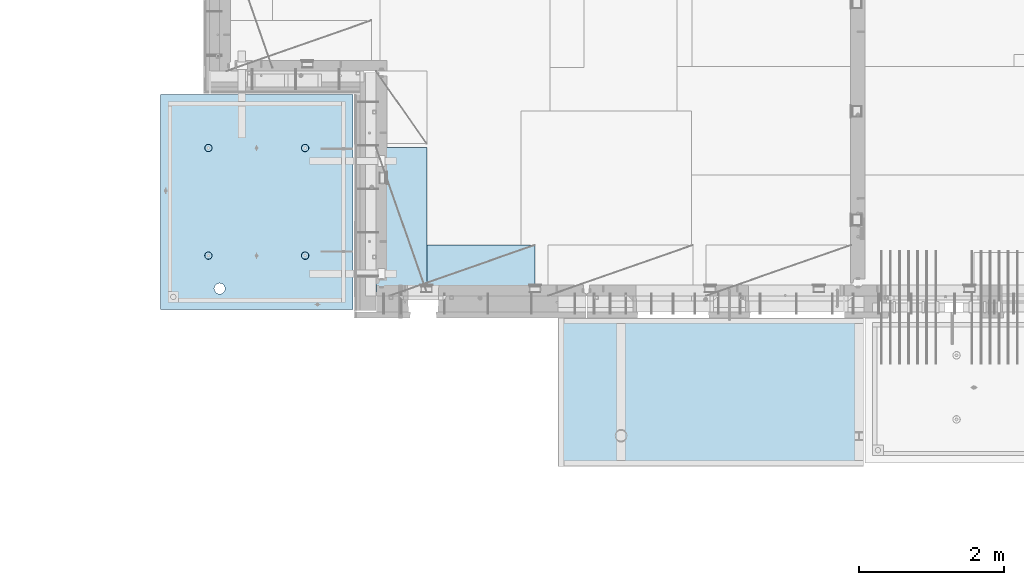
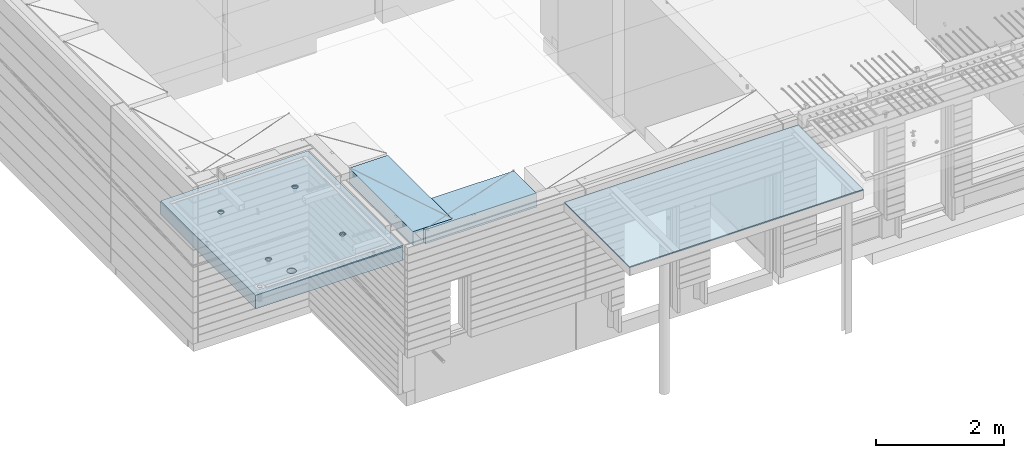
# One storey, part 178 of 325: 3 plates, 2 slabs, 4 elements without a shape of their own.
"""IFC2X3 building model written with IfcOpenShell, lengths in millimetres."""

from ifc_helpers import new_model, si_unit, frame, origin_with_axes, place, context, subcontext, project, spatial, faceted_brep, material, type_object, element, aggregate, save


model = new_model("IFC2X3")

# Units and contexts
model_context = context("Model", 3, precision=1e-05, world=origin_with_axes())
body_context = subcontext(model_context, "Body", "Model", "MODEL_VIEW")
ifc_project = project(units=[si_unit("LENGTHUNIT", "METRE", prefix="MILLI"), si_unit("AREAUNIT", "SQUARE_METRE"), si_unit("VOLUMEUNIT", "CUBIC_METRE"), si_unit("MASSUNIT", "GRAM", prefix="KILO"), si_unit("TIMEUNIT", "SECOND"), si_unit("PLANEANGLEUNIT", "RADIAN"), si_unit("SOLIDANGLEUNIT", "STERADIAN"), si_unit("THERMODYNAMICTEMPERATUREUNIT", "DEGREE_CELSIUS"), si_unit("LUMINOUSINTENSITYUNIT", "LUMEN")], contexts=[model_context])

# Site, building, storey
site_placement = place(None, origin_with_axes())
site = spatial("IfcSite", under=ifc_project, at=site_placement, CompositionType="ELEMENT")
building_placement = place(site_placement, origin_with_axes())
building = spatial("IfcBuilding", under=site, at=building_placement, CompositionType="ELEMENT")
storey_placement = place(building_placement, origin_with_axes())
storey = spatial("IfcBuildingStorey", under=building, at=storey_placement, Name="1", CompositionType="ELEMENT", Elevation=0.0)

# Assembly, slabs
assembly_1_placement = place(storey_placement, origin_with_axes())
assembly_1 = element("IfcElementAssembly", 1, at=assembly_1_placement, inside=storey, AssemblyPlace="NOTDEFINED", PredefinedType="REINFORCEMENT_UNIT")
ifc_material_1 = material(Name="CONCRETE/C35/45")
slab_type_1 = type_object("IfcSlabType", PredefinedType="NOTDEFINED")
slab_1_placement = place(assembly_1_placement, frame((9690.00344264774, 7659.99985681325, 84717.5), z_axis=(-1.0, 3.00000001838171e-08, 0.0), x_axis=(0.0, 1.0, 0.0)))
slab_1 = element("IfcSlab", 2, at=slab_1_placement, type_object=slab_type_1, material=ifc_material_1, PredefinedType="FLOOR", context=body_context, shape_type="Brep", body=[
    faceted_brep([(2970.0, 12.5, 2076.56396484375), (2970.0, 12.5, 2655.10375976563), (2970.0, 7.05330645262438, 2076.56396484375), (2970.0, 12.5, 0.0), (2969.99999999997, -12.5000027287315, -0.000215120240682154), (7.41420080885291e-08, 12.4999999999927, 0.0), (-7.41420080885291e-08, -12.5, -3.63797880709171e-12), (0.0, 12.5, 2655.00366210938), (2246.17288192116, -6.7539579669974, 610.235903379627), (2245.81872714612, 12.5, 611.325879700402), (2230.00000005311, 12.5, 608.820439463128), (2230.00000005311, -6.77809034052189, 607.672934085716), (2260.76019932669, -6.68392947182292, 617.673133503364), (2260.0890070157, 12.5, 618.596950465364), (2272.332530811, -6.57487936261168, 629.254531739907), (2271.41396524135, 12.5, 629.921908691014), (2279.75709784774, -6.43750647555862, 643.843854552742), (2278.68503600632, 12.5, 644.192188560603), (2282.30864751904, -6.2852774275234, 660.010915653605), (2281.19047624359, 12.5, 660.010915653605), (2279.73986529519, -6.13310092446045, 676.172377558725), (2278.68503600632, 12.5, 675.829642746608), (2272.30464795307, -5.995865551522, 690.747041485218), (2271.41396524135, 12.5, 690.099922616197), (2260.73231646608, -5.88698525390646, 702.310320338618), (2260.0890070157, 12.5, 701.424880841847), (2246.15564936427, -5.81709377811057, 709.732891570933), (2245.81872714612, 12.5, 708.695951606809), (2230.00000005311, -5.7930130083696, 712.290261666009), (2230.00000005311, 12.5, 711.201391844083), (2213.8443507625, -5.8170926610037, 709.732891507694), (2214.18127296011, 12.5, 708.695951606811), (2199.2676837145, -5.88698312871566, 702.310320236276), (2199.91099309052, 12.5, 701.424880841847), (2187.69535229405, -5.99586262571393, 690.747041382852), (2188.58603486487, 12.5, 690.099922616197), (2180.26013500581, -6.13309748387837, 676.172377495441), (2181.31496409991, 12.5, 675.829642746608), (2177.6913528026, -6.28527380865125, 660.010915653605), (2178.80952386264, 12.5, 660.010915653605), (2180.24290245339, -6.43750303260458, 643.843854616072), (2181.31496409991, 12.5, 644.192188560603), (2187.66746943631, -6.57487643294735, 629.254531842409), (2188.58603486487, 12.5, 629.921908691014), (2199.23980085403, -6.68392734277586, 617.673133605889), (2199.91099309052, 12.5, 618.596950465364), (2213.82711820565, -6.75395684751857, 610.235903443003), (2214.18127296011, 12.5, 611.325879700402), (761.172882674973, -6.75400078258826, 610.225900828256), (760.818727112381, 12.5, 611.315879572843), (745.000000019378, 12.5, 608.81043933557), (745.000000019378, -6.77813315729145, 607.662931409541), (775.760200790834, -6.68397228400863, 617.663131314152), (775.089006981969, 12.5, 618.586950337805), (787.33253283866, -6.57492216948594, 629.244530114656), (786.413965207619, 12.5, 629.911908563456), (794.757100236948, -6.437549275739, 643.833853637923), (793.685035972581, 12.5, 644.182188433044), (797.308650032492, -6.28532022031141, 660.000915526047), (796.190476209855, 12.5, 660.000915526047), (794.739867683551, -6.13314370981243, 676.162378218156), (793.685035972581, 12.5, 675.81964261905), (787.304649979378, -5.9959083302092, 690.737042854367), (786.413965207619, 12.5, 690.089922488638), (775.732317928869, -5.88702802728221, 702.300322270843), (775.089006981969, 12.5, 701.414880714288), (761.155650117242, -5.81713654809573, 709.722893864604), (760.818727112381, 12.5, 708.68595147925), (745.000000019378, -5.79305577717605, 712.280264084213), (745.000000019378, 12.5, 711.191391716524), (728.844349942063, -5.8171354309743, 709.722893801363), (729.181272926375, 12.5, 708.68595147925), (714.267682184241, -5.88702590207686, 702.300322168503), (714.910993056787, 12.5, 701.414880714288), (702.695350200273, -5.99590540440113, 690.737042752), (703.586034831136, 12.5, 690.089922488638), (695.260132549976, -6.1331402692449, 676.16237815487), (696.314964066174, 12.5, 675.81964261905), (692.691350221674, -6.28531660142471, 660.000915526047), (693.809523828902, 12.5, 660.000915526047), (695.242899996714, -6.43754583279951, 643.833853701251), (696.314964066174, 12.5, 644.182188433044), (702.667467341174, -6.57491923982161, 629.244530217156), (703.586034831136, 12.5, 629.911908563456), (714.239799322411, -6.68397015496157, 617.663131416677), (714.910993056787, 12.5, 618.586950337805), (728.827117384375, -6.75399966310943, 610.225900891632), (729.181272926375, 12.5, 611.315879572843), (760.941541335169, 5.82308796475991, 1945.93972725137), (760.818727091786, 12.5, 1946.31771062636), (744.999999998783, 12.5, 1943.81227038909), (744.999999998783, 5.79930078610778, 1943.4134192454), (775.320198478928, 5.89211475661432, 1953.2705735664), (775.089006961374, 12.5, 1953.58878139132), (786.72699673669, 5.99960498859582, 1964.68630888353), (786.413965187025, 12.5, 1964.91373961697), (794.045361100365, 6.13501286304381, 1979.06694274881), (793.685035951987, 12.5, 1979.18401948656), (796.560412832556, 6.28506439260673, 1995.00274657956), (796.190476189258, 12.5, 1995.00274657956), (794.028375046106, 6.43506412883289, 2010.93303130673), (793.685035951987, 12.5, 2010.82147367257), (786.699512721421, 6.57033645619231, 2025.29921596966), (786.413965187025, 12.5, 2025.09175354215), (775.292714461017, 6.67765930559835, 2036.69709108738), (775.089006961374, 12.5, 2036.41671176781), (760.924555276639, 6.74655103802797, 2044.01348819506), (760.818727091786, 12.5, 2043.68778253277), (744.999999998783, 6.7702873510425, 2046.53427709438), (744.999999998783, 12.5, 2046.19322277004), (729.075444741182, 6.7465521391714, 2044.01348813272), (729.18127290578, 12.5, 2043.68778253277), (714.70728560984, 6.67766140039021, 2036.6970909865), (714.910993036192, 12.5, 2036.41671176781), (703.300487415023, 6.57033934014908, 2025.29921586876), (703.586034810542, 12.5, 2025.09175354216), (695.971625143447, 6.43506752018584, 2010.93303124435), (696.314964045579, 12.5, 2010.82147367257), (693.439587377337, 6.28506795971771, 1995.00274657956), (693.809523808306, 12.5, 1995.00274657956), (695.954639089321, 6.13501625673962, 1979.06694281123), (696.314964045579, 12.5, 1979.18401948656), (703.273003399938, 5.99960787635064, 1964.68630898457), (703.586034810542, 12.5, 1964.91373961697), (714.679801592063, 5.89211685521877, 1953.27057366746), (714.910993036192, 12.5, 1953.58878139132), (729.058458682694, 5.82308906823164, 1945.93972731384), (729.18127290578, 12.5, 1946.31771062636), (2178.80952377932, 12.5, 1995.00274667064), (2178.43958429075, 6.28501659208268, 1995.00274667064), (2180.95463615188, 6.13496488021337, 1979.06694195729), (2181.31496401659, 12.5, 1979.18401957764), (2181.31496401659, 12.5, 2010.82147376364), (2180.97162220701, 6.43501616145659, 2010.93303228012), (2188.58603478155, 12.5, 2025.09175363323), (2188.3004849132, 6.57028798943793, 2025.29921775646), (2199.9109930072, 12.5, 2036.41671185888), (2199.70728378446, 6.6776100560528, 2036.6970935501), (2214.18127287679, 12.5, 2043.68778262385), (2214.07544376785, 6.74650079890853, 2044.0134911302), (2229.9999999698, 12.5, 2046.19322286112), (2229.9999999698, 6.77023601217661, 2046.53428024135), (2245.8187270628, 12.5, 2043.68778262385), (2245.924556192, 6.7464996977651, 2044.01349119253), (2260.08900693239, 12.5, 2036.41671185888), (2260.29271622843, 6.67760796126095, 2036.69709365098), (2271.41396515804, 12.5, 2025.09175363323), (2271.69951516527, 6.57028510548116, 2025.29921785736), (2278.685035923, 12.5, 2010.82147376364), (2279.02837792456, 6.43501277010364, 2010.9330323425), (2281.19047616027, 12.5, 1995.00274667064), (2281.56041586117, 6.2850130249717, 1995.00274667064), (2278.685035923, 12.5, 1979.18401957764), (2279.04536397983, 6.13496148651757, 1979.06694189487), (2271.41396515804, 12.5, 1964.91373970805), (2271.72699918216, 5.99955360403692, 1964.68630717681), (2260.08900693239, 12.5, 1953.5887814824), (2260.32020024797, 5.89206336568168, 1953.2705711827), (2245.8187270628, 12.5, 1946.31771071744), (2245.94154225154, 5.82303656973818, 1945.93972443295), (252.498938391112, 4.21397329043248, 1775.04642620131), (236.965929802121, 4.32620222466358, 1786.96532289615), (225.047033107278, 4.4724615313462, 1802.49833148514), (217.554501419431, 4.6427838804666, 1820.58690310245), (214.998938391112, 4.82556208534515, 1839.99833148514), (217.554501419431, 5.00834011344705, 1859.40975986783), (225.047033107278, 5.17866194414091, 1877.49833148514), (236.965929802121, 5.3249204261956, 1893.03134007413), (252.498938391112, 5.43714828572411, 1904.95023676897), (270.587510008422, 5.5076973795949, 1912.44276845682), (289.998938391112, 5.53175990360614, 1914.99833148514), (309.410366773801, 5.50769603654044, 1912.44276845682), (327.498938391112, 5.43714569117583, 1904.95023676897), (343.031946980102, 5.32491675694473, 1893.03134007413), (354.950843674945, 5.17865745026211, 1877.49833148514), (362.443375362792, 5.00833510115626, 1859.40975986783), (364.998938391112, 4.8255568962777, 1839.99833148514), (362.443375362792, 4.64277886817581, 1820.58690310245), (354.950843674945, 4.47245703748195, 1802.49833148514), (343.031946980102, 4.32619855542725, 1786.96532289615), (327.498938391112, 4.21397069589875, 1775.04642620131), (309.410366773801, 4.14342160202796, 1767.55389451346), (289.998938391112, 4.11935907801671, 1764.99833148514), (270.587510008422, 4.14342294506787, 1767.55389451346), (2199.67979976505, 5.89206546428613, 1953.27057128376), (2188.27300089649, 5.99955649179174, 1964.68630727784), (2229.9999999698, 5.79924938967451, 1943.41341627717), (2214.05845770835, 5.82303767320991, 1945.93972449542), (2188.58603478155, 12.5, 1964.91373970805), (2199.9109930072, 12.5, 1953.5887814824), (2214.18127287679, 12.5, 1946.31771071744), (2229.9999999698, 12.5, 1943.81227048017), (327.498938391112, 12.5, 1775.04642620131), (343.031946980102, 12.5, 1786.96532289615), (354.950843674945, 12.5, 1802.49833148514), (362.443375362792, 12.5, 1820.58690310245), (364.998938391112, 12.5, 1839.99833148514), (362.443375362792, 12.5, 1859.40975986783), (354.950843674945, 12.5, 1877.49833148514), (343.031946980102, 12.5, 1893.03134007413), (327.498938391112, 12.5, 1904.95023676897), (309.410366773801, 12.5, 1912.44276845682), (289.998938391112, 12.5, 1914.99833148514), (270.587510008422, 12.5, 1912.44276845682), (252.498938391112, 12.5, 1904.95023676897), (236.965929802121, 12.5, 1893.03134007413), (225.047033107278, 12.5, 1877.49833148514), (217.554501419431, 12.5, 1859.40975986783), (214.998938391112, 12.5, 1839.99833148514), (217.554501419431, 12.5, 1820.58690310245), (225.047033107278, 12.5, 1802.49833148514), (236.965929802121, 12.5, 1786.96532289615), (252.498938391112, 12.5, 1775.04642620131), (270.587510008422, 12.5, 1767.55389451346), (289.998938391112, 12.5, 1764.99833148514), (309.410366773801, 12.5, 1767.55389451346)], [[[0, 1, 2]], [[3, 0, 2, 4]], [[5, 3, 4, 6]], [[5, 6, 7]], [[8, 9, 10, 11]], [[12, 13, 9, 8]], [[14, 15, 13, 12]], [[16, 17, 15, 14]], [[18, 19, 17, 16]], [[20, 21, 19, 18]], [[21, 20, 22, 23]], [[23, 22, 24, 25]], [[25, 24, 26, 27]], [[27, 26, 28, 29]], [[29, 28, 30, 31]], [[31, 30, 32, 33]], [[33, 32, 34, 35]], [[35, 34, 36, 37]], [[37, 36, 38, 39]], [[40, 41, 39, 38]], [[42, 43, 41, 40]], [[44, 45, 43, 42]], [[46, 47, 45, 44]], [[11, 10, 47, 46]], [[48, 49, 50, 51]], [[52, 53, 49, 48]], [[54, 55, 53, 52]], [[56, 57, 55, 54]], [[58, 59, 57, 56]], [[60, 61, 59, 58]], [[61, 60, 62, 63]], [[63, 62, 64, 65]], [[65, 64, 66, 67]], [[67, 66, 68, 69]], [[69, 68, 70, 71]], [[71, 70, 72, 73]], [[73, 72, 74, 75]], [[75, 74, 76, 77]], [[77, 76, 78, 79]], [[80, 81, 79, 78]], [[82, 83, 81, 80]], [[84, 85, 83, 82]], [[86, 87, 85, 84]], [[51, 50, 87, 86]], [[88, 89, 90, 91]], [[92, 93, 89, 88]], [[94, 95, 93, 92]], [[96, 97, 95, 94]], [[98, 99, 97, 96]], [[100, 101, 99, 98]], [[102, 103, 101, 100]], [[104, 105, 103, 102]], [[105, 104, 106, 107]], [[107, 106, 108, 109]], [[109, 108, 110, 111]], [[111, 110, 112, 113]], [[113, 112, 114, 115]], [[115, 114, 116, 117]], [[117, 116, 118, 119]], [[119, 118, 120, 121]], [[121, 120, 122, 123]], [[124, 125, 123, 122]], [[126, 127, 125, 124]], [[91, 90, 127, 126]], [[128, 129, 130, 131]], [[132, 133, 129, 128]], [[134, 135, 133, 132]], [[136, 137, 135, 134]], [[138, 139, 137, 136]], [[140, 141, 139, 138]], [[142, 143, 141, 140]], [[144, 145, 143, 142]], [[145, 144, 146, 147]], [[147, 146, 148, 149]], [[149, 148, 150, 151]], [[151, 150, 152, 153]], [[153, 152, 154, 155]], [[155, 154, 156, 157]], [[157, 156, 158, 159]], [[4, 2, 1, 7, 6], [160, 161, 162, 163, 164, 165, 166, 167, 168, 169, 170, 171, 172, 173, 174, 175, 176, 177, 178, 179, 180, 181, 182, 183], [184, 185, 130, 129, 133, 135, 137, 139, 141, 143, 145, 147, 149, 151, 153, 155, 157, 159, 186, 187], [124, 122, 120, 118, 116, 114, 112, 110, 108, 106, 104, 102, 100, 98, 96, 94, 92, 88, 91, 126], [84, 82, 80, 78, 76, 74, 72, 70, 68, 66, 64, 62, 60, 58, 56, 54, 52, 48, 51, 86], [44, 42, 40, 38, 36, 34, 32, 30, 28, 26, 24, 22, 20, 18, 16, 14, 12, 8, 11, 46]], [[131, 130, 185, 188]], [[184, 189, 188, 185]], [[187, 190, 189, 184]], [[186, 191, 190, 187]], [[159, 158, 191, 186]], [[0, 3, 5, 7, 1], [192, 193, 194, 195, 196, 197, 198, 199, 200, 201, 202, 203, 204, 205, 206, 207, 208, 209, 210, 211, 212, 213, 214, 215], [156, 154, 152, 150, 148, 146, 144, 142, 140, 138, 136, 134, 132, 128, 131, 188, 189, 190, 191, 158], [93, 95, 97, 99, 101, 103, 105, 107, 109, 111, 113, 115, 117, 119, 121, 123, 125, 127, 90, 89], [53, 55, 57, 59, 61, 63, 65, 67, 69, 71, 73, 75, 77, 79, 81, 83, 85, 87, 50, 49], [13, 15, 17, 19, 21, 23, 25, 27, 29, 31, 33, 35, 37, 39, 41, 43, 45, 47, 10, 9]], [[182, 214, 213, 183]], [[181, 215, 214, 182]], [[180, 192, 215, 181]], [[179, 193, 192, 180]], [[178, 194, 193, 179]], [[177, 195, 194, 178]], [[176, 196, 195, 177]], [[175, 197, 196, 176]], [[174, 198, 197, 175]], [[173, 199, 198, 174]], [[172, 200, 199, 173]], [[171, 201, 200, 172]], [[170, 202, 201, 171]], [[169, 203, 202, 170]], [[168, 204, 203, 169]], [[167, 205, 204, 168]], [[166, 206, 205, 167]], [[165, 207, 206, 166]], [[164, 208, 207, 165]], [[163, 209, 208, 164]], [[162, 210, 209, 163]], [[161, 211, 210, 162]], [[160, 212, 211, 161]], [[183, 213, 212, 160]]]),
])
slab_type_2 = type_object("IfcSlabType", PredefinedType="NOTDEFINED")
slab_2_placement = place(assembly_1_placement, frame((9690.00344264774, 7659.99985681325, 84575.0), z_axis=(-0.999999999997437, -2.26400000064461e-06, 0.0), x_axis=(-2.2639999995273e-06, 0.999999999997437, 0.0)))
slab_2 = element("IfcSlab", 3, at=slab_2_placement, type_object=slab_type_2, material=ifc_material_1, PredefinedType="FLOOR", context=body_context, shape_type="Brep", body=[
    faceted_brep([(2245.45536387143, -110.0, 1947.44471589559), (2259.39379322965, -110.0, 1954.54665968234), (2270.4554059745, -110.0, 1965.60822114567), (2277.55741437973, -110.0, 1979.54661757913), (2280.00462438004, -110.0, 1994.99746162528), (2277.55748600988, -110.0, 2010.44831701654), (2270.45554222312, -110.0, 2024.38674637476), (2259.39398075979, -110.0, 2035.44835911961), (2245.45558432633, -110.0, 2042.55036752485), (2230.00474028018, -110.0, 2044.99757752515), (2214.55388488892, -110.0, 2042.55043915498), (2200.6154555307, -110.0, 2035.44849536823), (2189.55384278585, -110.0, 2024.3869339049), (2182.45183438062, -110.0, 2010.44853747144), (2180.00462438031, -110.0, 1994.99769342529), (2182.45176275048, -110.0, 1979.54683803403), (2189.55370653723, -110.0, 1965.60840867581), (2200.61526800056, -110.0, 1954.54679593096), (2214.55366443402, -110.0, 1947.44478752572), (2230.00450848018, -110.0, 1944.99757752542), (2260.09353534512, -130.0, 1953.58354259084), (2245.82323862122, -130.0, 1946.3125049044), (2271.41851982199, -130.0, 1964.9084745652), (2278.68962366544, -130.0, 1979.17873758041), (2281.19510057052, -130.0, 1994.99745886576), (2278.68969700106, -130.0, 2010.81619176633), (2271.41865931462, -130.0, 2025.08648849022), (2260.09372734026, -130.0, 2036.4114729671), (2245.82346432505, -130.0, 2043.68257681055), (2230.0047430397, -130.0, 2046.18805371562), (2214.18601013913, -130.0, 2043.68265014617), (2199.91571341524, -130.0, 2036.41161245973), (2188.59072893836, -130.0, 2025.08668048537), (2181.31962509491, -130.0, 2010.81641747016), (2178.81414818984, -130.0, 1994.99769618481), (2181.31955175929, -130.0, 1979.17896328424), (2188.59058944573, -130.0, 1964.90866656035), (2199.91552142009, -130.0, 1953.58368208347), (2214.1857844353, -130.0, 1946.31257824002), (2230.00450572065, -130.0, 1943.80710133495), (760.455363904408, -110.0, 1947.44815803451), (774.393793262629, -110.0, 1954.55010182126), (785.455406007481, -110.0, 1965.61166328459), (792.557414412711, -110.0, 1979.55005971805), (795.004624413019, -110.0, 1995.00090376421), (792.557486042851, -110.0, 2010.45175915546), (785.455542256102, -110.0, 2024.39018851368), (774.393980792767, -110.0, 2035.45180125853), (760.455584359308, -110.0, 2042.55380966377), (745.004740313152, -110.0, 2045.00101966407), (729.553884921896, -110.0, 2042.55388129391), (715.615455563677, -110.0, 2035.45193750716), (704.553842818825, -110.0, 2024.39037604382), (697.451834413594, -110.0, 2010.45197961036), (695.004624413286, -110.0, 1995.00113556421), (697.451762783454, -110.0, 1979.55028017295), (704.553706570203, -110.0, 1965.61185081473), (715.615268033538, -110.0, 1954.55023806988), (729.553664466996, -110.0, 1947.44822966465), (745.004508513151, -110.0, 1945.00101966434), (760.823238654199, -130.0, 1946.31594704332), (745.004505753628, -130.0, 1943.81054347387), (775.093535378091, -130.0, 1953.58698472976), (786.418519854964, -130.0, 1964.91191670413), (793.689623698416, -130.0, 1979.18217971933), (796.195100603492, -130.0, 1995.00090100468), (793.689697034035, -130.0, 2010.81963390525), (786.418659347601, -130.0, 2025.08993062915), (775.093727373234, -130.0, 2036.41491510602), (760.823464358025, -130.0, 2043.68601894947), (745.004743072675, -130.0, 2046.19149585455), (729.186010172105, -130.0, 2043.68609228509), (714.915713448214, -130.0, 2036.41505459866), (703.590728971341, -130.0, 2025.09012262429), (696.319625127888, -130.0, 2010.81985960908), (693.814148222813, -130.0, 1995.00113832373), (696.319551792269, -130.0, 1979.18240542316), (703.590589478705, -130.0, 1964.91210869927), (714.915521453071, -130.0, 1953.5871242224), (729.185784468278, -130.0, 1946.31602037894), (2970.0, -130.0, 1.11504050437361e-09), (0.0, -130.0, -3.63797880709171e-12), (0.0, 130.0, -1.81898940354586e-12), (2970.0, 130.0, 1.11504050437361e-09), (2970.0048828125, -130.0, 2076.55712890625), (2970.0048828125, 130.0, 2076.55712890625), (2970.00610351563, -130.0, 2655.0966796875), (2970.00610351563, 130.0, 2655.0966796875), (0.00277573079893045, -130.0, 2655.00366210937), (0.00277573079893045, 130.0, 2655.00366210937), (327.503052947852, 130.0, 1775.045667054), (343.036089164803, 130.0, 1786.9645277433), (354.955021865127, 130.0, 1802.49750870425), (362.447595482264, 130.0, 1820.58606295382), (365.003203506267, 130.0, 1839.99748541266), (362.447685473646, 130.0, 1859.40891971909), (354.955195715128, 130.0, 1877.49750870404), (343.036335025831, 130.0, 1893.030544921), (327.503354064885, 130.0, 1904.94947762132), (309.41479981531, 130.0, 1912.44205123846), (290.003377356469, 130.0, 1914.99765926246), (270.591943050036, 130.0, 1912.44214122984), (252.503354065087, 130.0, 1904.94965147132), (236.970317848134, 130.0, 1893.03079078202), (225.051385147811, 130.0, 1877.49780982108), (217.558811530675, 130.0, 1859.4092555715), (215.00320350667, 130.0, 1839.99783311266), (217.558721539292, 130.0, 1820.58639880623), (225.05121129781, 130.0, 1802.49780982128), (236.970071987106, 130.0, 1786.96477360433), (252.503052948054, 130.0, 1775.045840904), (270.591607197626, 130.0, 1767.55326728687), (290.003029656469, 130.0, 1764.99765926286), (309.4144639629, 130.0, 1767.55317729549), (309.4144639629, -130.0, 1767.55317729549), (290.003029656469, -130.0, 1764.99765926286), (327.503052947852, -130.0, 1775.045667054), (343.036089164803, -130.0, 1786.9645277433), (354.955021865127, -130.0, 1802.49750870425), (362.447595482264, -130.0, 1820.58606295382), (365.003203506267, -130.0, 1839.99748541266), (362.447685473646, -130.0, 1859.40891971909), (354.955195715128, -130.0, 1877.49750870404), (343.036335025831, -130.0, 1893.030544921), (327.503354064885, -130.0, 1904.94947762132), (309.41479981531, -130.0, 1912.44205123846), (290.003377356469, -130.0, 1914.99765926246), (270.591943050036, -130.0, 1912.44214122984), (252.503354065087, -130.0, 1904.94965147132), (236.970317848134, -130.0, 1893.03079078202), (225.051385147811, -130.0, 1877.49780982108), (217.558811530675, -130.0, 1859.4092555715), (215.00320350667, -130.0, 1839.99783311266), (217.558721539292, -130.0, 1820.58639880623), (225.05121129781, -130.0, 1802.49780982128), (236.970071987106, -130.0, 1786.96477360433), (252.503052948054, -130.0, 1775.045840904), (270.591607197626, -130.0, 1767.55326728687), (760.452269390758, -110.0, 612.446326984578), (774.390698748979, -110.0, 619.548270771327), (785.452311493831, -110.0, 630.609832234661), (792.554319899062, -110.0, 644.54822866812), (795.001529899369, -110.0, 659.999072714278), (792.554391529202, -110.0, 675.449928105532), (785.452447742453, -110.0, 689.388357463751), (774.390886279118, -110.0, 700.449970208605), (760.452489845658, -110.0, 707.551978613836), (745.001645799503, -110.0, 709.999188614142), (729.550790408246, -110.0, 707.552050243974), (715.612361050027, -110.0, 700.450106457225), (704.550748305175, -110.0, 689.388544993892), (697.448739899944, -110.0, 675.450148560432), (695.001529899637, -110.0, 659.999304514276), (697.448668269804, -110.0, 644.54844912302), (704.550612056553, -110.0, 630.610019764801), (715.612173519889, -110.0, 619.548407019947), (729.550569953346, -110.0, 612.446398614717), (745.001413999502, -110.0, 609.999188614411), (760.820144140549, -130.0, 611.314115993395), (745.001411239979, -130.0, 608.808712423936), (775.090440864442, -130.0, 618.585153679829), (786.415425341314, -130.0, 629.910085654195), (793.686529184766, -130.0, 644.180348669403), (796.192006089843, -130.0, 659.999069954752), (793.686602520385, -130.0, 675.817802855323), (786.415564833951, -130.0, 690.088099579216), (775.090632859585, -130.0, 701.41308405609), (760.820369844376, -130.0, 708.68418789954), (745.001648559026, -130.0, 711.189664804615), (729.182915658455, -130.0, 708.684261235159), (714.912618934564, -130.0, 701.413223548725), (703.587634457692, -130.0, 690.088291574357), (696.316530614238, -130.0, 675.81802855915), (693.811053709163, -130.0, 659.999307273802), (696.316457278619, -130.0, 644.180574373229), (703.587494965055, -130.0, 629.910277649336), (714.912426939421, -130.0, 618.585293172464), (729.182689954629, -130.0, 611.314189329014), (2245.45226944368, -110.0, 612.452884882137), (2259.3906988019, -110.0, 619.554828668886), (2270.45231154675, -110.0, 630.61639013222), (2277.55431995199, -110.0, 644.554786565679), (2280.00152995229, -110.0, 660.005630611837), (2277.55439158212, -110.0, 675.456486003091), (2270.45244779537, -110.0, 689.39491536131), (2259.39088633204, -110.0, 700.456528106164), (2245.45248989858, -110.0, 707.558536511395), (2230.00164585242, -110.0, 710.005746511701), (2214.55079046117, -110.0, 707.558608141533), (2200.61236110295, -110.0, 700.456664354784), (2189.5507483581, -110.0, 689.395102891451), (2182.44873995286, -110.0, 675.456706457991), (2180.00152995256, -110.0, 660.005862411836), (2182.44866832273, -110.0, 644.555007020579), (2189.55061210948, -110.0, 630.61657766236), (2200.61217357281, -110.0, 619.554964917506), (2214.55057000627, -110.0, 612.452956512276), (2230.00141405243, -110.0, 610.00574651197), (2245.82014419347, -130.0, 611.320673890954), (2230.0014112929, -130.0, 608.815270321495), (2260.09044091736, -130.0, 618.591711577388), (2271.41542539424, -130.0, 629.916643551753), (2278.68652923769, -130.0, 644.186906566962), (2281.19200614276, -130.0, 660.005627852312), (2278.68660257331, -130.0, 675.824360752882), (2271.41556488687, -130.0, 690.094657476773), (2260.09063291251, -130.0, 701.419641953647), (2245.8203698973, -130.0, 708.690745797099), (2230.00164861195, -130.0, 711.196222702174), (2214.18291571138, -130.0, 708.690819132718), (2199.91261898749, -130.0, 701.419781446282), (2188.58763451061, -130.0, 690.094849471916), (2181.31653066716, -130.0, 675.824586456709), (2178.81105376209, -130.0, 660.005865171361), (2181.31645733154, -130.0, 644.187132270788), (2188.58749501798, -130.0, 629.916835546896), (2199.91242699234, -130.0, 618.591851070023), (2214.18269000755, -130.0, 611.320747226573)], [[[0, 1, 2, 3, 4, 5, 6, 7, 8, 9, 10, 11, 12, 13, 14, 15, 16, 17, 18, 19]], [[20, 1, 0, 21]], [[22, 2, 1, 20]], [[23, 3, 2, 22]], [[24, 4, 3, 23]], [[25, 5, 4, 24]], [[26, 6, 5, 25]], [[27, 7, 6, 26]], [[28, 8, 7, 27]], [[29, 9, 8, 28]], [[30, 10, 9, 29]], [[31, 11, 10, 30]], [[32, 12, 11, 31]], [[33, 13, 12, 32]], [[34, 14, 13, 33]], [[35, 15, 14, 34]], [[36, 16, 15, 35]], [[37, 17, 16, 36]], [[38, 18, 17, 37]], [[39, 19, 18, 38]], [[21, 0, 19, 39]], [[40, 41, 42, 43, 44, 45, 46, 47, 48, 49, 50, 51, 52, 53, 54, 55, 56, 57, 58, 59]], [[60, 40, 59, 61]], [[62, 41, 40, 60]], [[63, 42, 41, 62]], [[64, 43, 42, 63]], [[65, 44, 43, 64]], [[66, 45, 44, 65]], [[67, 46, 45, 66]], [[68, 47, 46, 67]], [[69, 48, 47, 68]], [[70, 49, 48, 69]], [[71, 50, 49, 70]], [[72, 51, 50, 71]], [[73, 52, 51, 72]], [[74, 53, 52, 73]], [[75, 54, 53, 74]], [[76, 55, 54, 75]], [[77, 56, 55, 76]], [[78, 57, 56, 77]], [[79, 58, 57, 78]], [[61, 59, 58, 79]], [[80, 81, 82, 83]], [[84, 80, 83, 85]], [[86, 84, 85, 87]], [[88, 86, 87, 89]], [[81, 88, 89, 82]], [[87, 85, 83, 82, 89], [90, 91, 92, 93, 94, 95, 96, 97, 98, 99, 100, 101, 102, 103, 104, 105, 106, 107, 108, 109, 110, 111, 112, 113]], [[114, 113, 112, 115]], [[116, 90, 113, 114]], [[117, 91, 90, 116]], [[118, 92, 91, 117]], [[119, 93, 92, 118]], [[120, 94, 93, 119]], [[121, 95, 94, 120]], [[122, 96, 95, 121]], [[123, 97, 96, 122]], [[124, 98, 97, 123]], [[125, 99, 98, 124]], [[126, 100, 99, 125]], [[127, 101, 100, 126]], [[128, 102, 101, 127]], [[129, 103, 102, 128]], [[130, 104, 103, 129]], [[131, 105, 104, 130]], [[132, 106, 105, 131]], [[133, 107, 106, 132]], [[134, 108, 107, 133]], [[135, 109, 108, 134]], [[136, 110, 109, 135]], [[137, 111, 110, 136]], [[115, 112, 111, 137]], [[138, 139, 140, 141, 142, 143, 144, 145, 146, 147, 148, 149, 150, 151, 152, 153, 154, 155, 156, 157]], [[158, 138, 157, 159]], [[160, 139, 138, 158]], [[161, 140, 139, 160]], [[162, 141, 140, 161]], [[163, 142, 141, 162]], [[164, 143, 142, 163]], [[165, 144, 143, 164]], [[166, 145, 144, 165]], [[167, 146, 145, 166]], [[168, 147, 146, 167]], [[169, 148, 147, 168]], [[170, 149, 148, 169]], [[171, 150, 149, 170]], [[172, 151, 150, 171]], [[173, 152, 151, 172]], [[174, 153, 152, 173]], [[175, 154, 153, 174]], [[176, 155, 154, 175]], [[177, 156, 155, 176]], [[159, 157, 156, 177]], [[178, 179, 180, 181, 182, 183, 184, 185, 186, 187, 188, 189, 190, 191, 192, 193, 194, 195, 196, 197]], [[198, 178, 197, 199]], [[200, 179, 178, 198]], [[201, 180, 179, 200]], [[202, 181, 180, 201]], [[203, 182, 181, 202]], [[204, 183, 182, 203]], [[205, 184, 183, 204]], [[206, 185, 184, 205]], [[207, 186, 185, 206]], [[208, 187, 186, 207]], [[209, 188, 187, 208]], [[210, 189, 188, 209]], [[211, 190, 189, 210]], [[212, 191, 190, 211]], [[213, 192, 191, 212]], [[214, 193, 192, 213]], [[215, 194, 193, 214]], [[216, 195, 194, 215]], [[217, 196, 195, 216]], [[199, 197, 196, 217]], [[80, 84, 86, 88, 81], [37, 36, 35, 34, 33, 32, 31, 30, 29, 28, 27, 26, 25, 24, 23, 22, 20, 21, 39, 38], [216, 215, 214, 213, 212, 211, 210, 209, 208, 207, 206, 205, 204, 203, 202, 201, 200, 198, 199, 217], [176, 175, 174, 173, 172, 171, 170, 169, 168, 167, 166, 165, 164, 163, 162, 161, 160, 158, 159, 177], [136, 135, 134, 133, 132, 131, 130, 129, 128, 127, 126, 125, 124, 123, 122, 121, 120, 119, 118, 117, 116, 114, 115, 137], [78, 77, 76, 75, 74, 73, 72, 71, 70, 69, 68, 67, 66, 65, 64, 63, 62, 60, 61, 79]]]),
])
aggregate(assembly_1, [slab_1, slab_2])

# Assembly, plate
assembly_2_placement = place(storey_placement, origin_with_axes())
assembly_2 = element("IfcElementAssembly", 4, at=assembly_2_placement, inside=storey, Name="Steel Assembly", AssemblyPlace="NOTDEFINED", PredefinedType="RIGID_FRAME")
ifc_material_2 = material(Name="STEEL/Steel_Undefined")
plate_type_1 = type_object("IfcPlateType", PredefinedType="NOTDEFINED")
plate_1_placement = place(assembly_2_placement, frame((16734.9998568133, 7524.99655735226, 84634.22), z_axis=(-1.11800000013248e-06, -0.999999999999375, 0.0), x_axis=(-0.999999999999093, 1.34699999998405e-06, 0.0)))
plate_1 = element("IfcPlate", 5, at=plate_1_placement, type_object=plate_type_1, material=ifc_material_2, context=body_context, shape_type="Brep", body=[
    faceted_brep([(0.0, -10.0, 0.0), (-0.000138975170557387, -10.0, 2030.00366210937), (-0.000138975170557387, 10.0, 2030.00366210937), (0.0, 10.0, 0.0), (4215.4697265625, -10.0, 2030.00366210937), (4215.4697265625, 10.0, 2030.00366210937), (4215.4697265625, -10.0, -1.8007995095104e-10), (4215.4697265625, 10.0, -1.8007995095104e-10)], [[[0, 1, 2, 3]], [[1, 4, 5, 2]], [[4, 6, 7, 5]], [[6, 0, 3, 7]], [[5, 7, 3, 2]], [[6, 4, 1, 0]]]),
])
aggregate(assembly_2, [plate_1])

assembly_3_placement = place(storey_placement, origin_with_axes())
assembly_3 = element("IfcElementAssembly", 6, at=assembly_3_placement, inside=storey, Name="Steel Assembly", AssemblyPlace="NOTDEFINED", PredefinedType="NOTDEFINED")
ifc_material_3 = material()
plate_type_2 = type_object("IfcPlateType", PredefinedType="NOTDEFINED")
plate_2_placement = place(assembly_3_placement, frame((10009.9998779297, 9900.0, 84595.3), z_axis=(1.0, 0.0, 0.0), x_axis=(0.0, -1.0, 0.0)))
plate_2 = element("IfcPlate", 7, at=plate_2_placement, type_object=plate_type_2, material=ifc_material_3, Name="RE1", context=body_context, shape_type="Brep", body=[
    faceted_brep([(1.81898940354586e-12, -135.0, 1.81898940354586e-12), (0.0, -135.0, 699.999999999996), (0.0, 135.0, 699.999999999996), (1.81898940354586e-12, 135.0, 1.81898940354586e-12), (1999.99951171875, -135.0, 699.999999999993), (1999.99951171875, 135.0, 699.999999999993), (2000.0, -135.0, -3.63797880709171e-12), (2000.0, 135.0, -3.63797880709171e-12)], [[[0, 1, 2, 3]], [[1, 4, 5, 2]], [[4, 6, 7, 5]], [[6, 0, 3, 7]], [[5, 7, 3, 2]], [[6, 4, 1, 0]]]),
])
aggregate(assembly_3, [plate_2])

assembly_4_placement = place(storey_placement, origin_with_axes())
assembly_4 = element("IfcElementAssembly", 8, at=assembly_4_placement, inside=storey, Name="Steel Assembly", AssemblyPlace="NOTDEFINED", PredefinedType="NOTDEFINED")
plate_3_placement = place(assembly_4_placement, frame((10200.0008542386, 7850.00010363356, 84595.3), z_axis=(0.0, 1.0, 0.0), x_axis=(1.0, 0.0, 0.0)))
plate_3 = element("IfcPlate", 9, at=plate_3_placement, type_object=plate_type_2, material=ifc_material_3, Name="RE1", context=body_context, shape_type="Brep", body=[
    faceted_brep([(1.81898940354586e-12, -135.0, 1.81898940354586e-12), (0.0, -135.0, 699.999999999996), (0.0, 135.0, 699.999999999996), (1.81898940354586e-12, 135.0, 1.81898940354586e-12), (1999.99951171875, -135.0, 699.999999999993), (1999.99951171875, 135.0, 699.999999999993), (2000.0, -135.0, -3.63797880709171e-12), (2000.0, 135.0, -3.63797880709171e-12)], [[[0, 1, 2, 3]], [[1, 4, 5, 2]], [[4, 6, 7, 5]], [[6, 0, 3, 7]], [[5, 7, 3, 2]], [[6, 4, 1, 0]]]),
])
aggregate(assembly_4, [plate_3])

save(model, "model.ifc")
